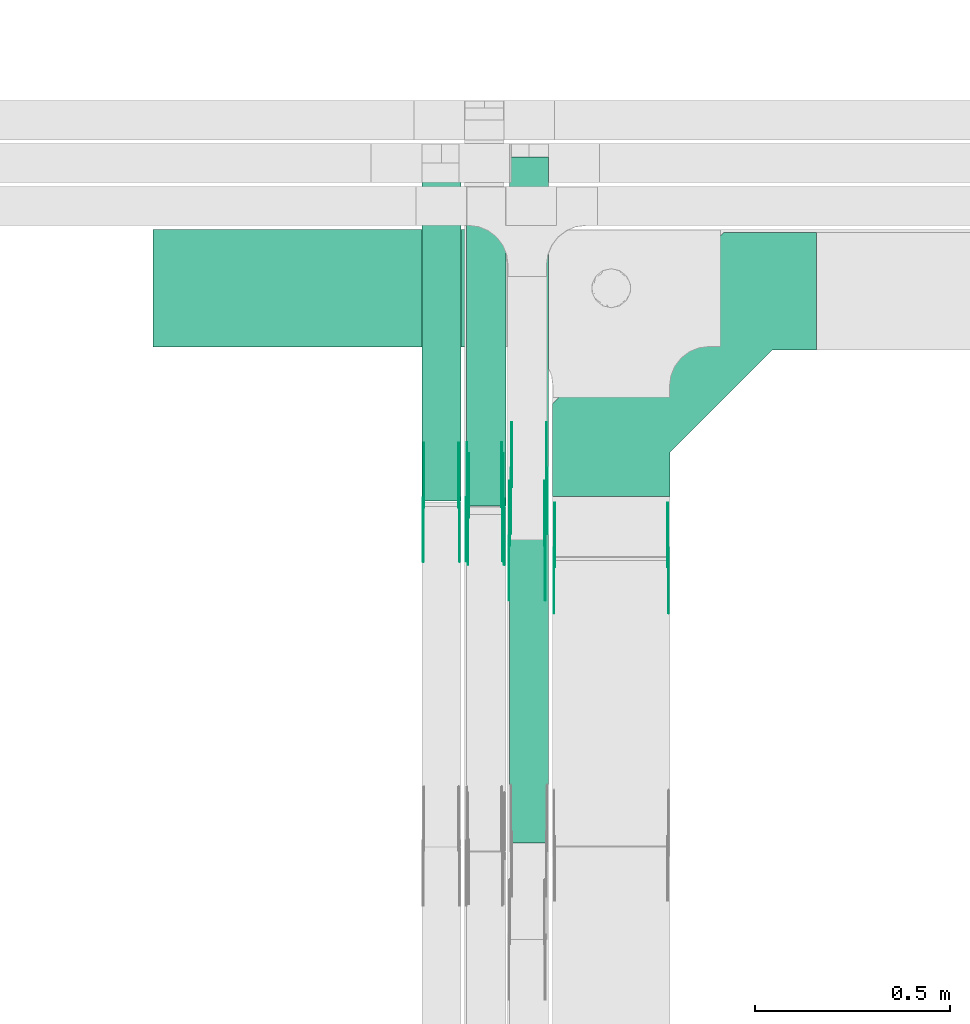
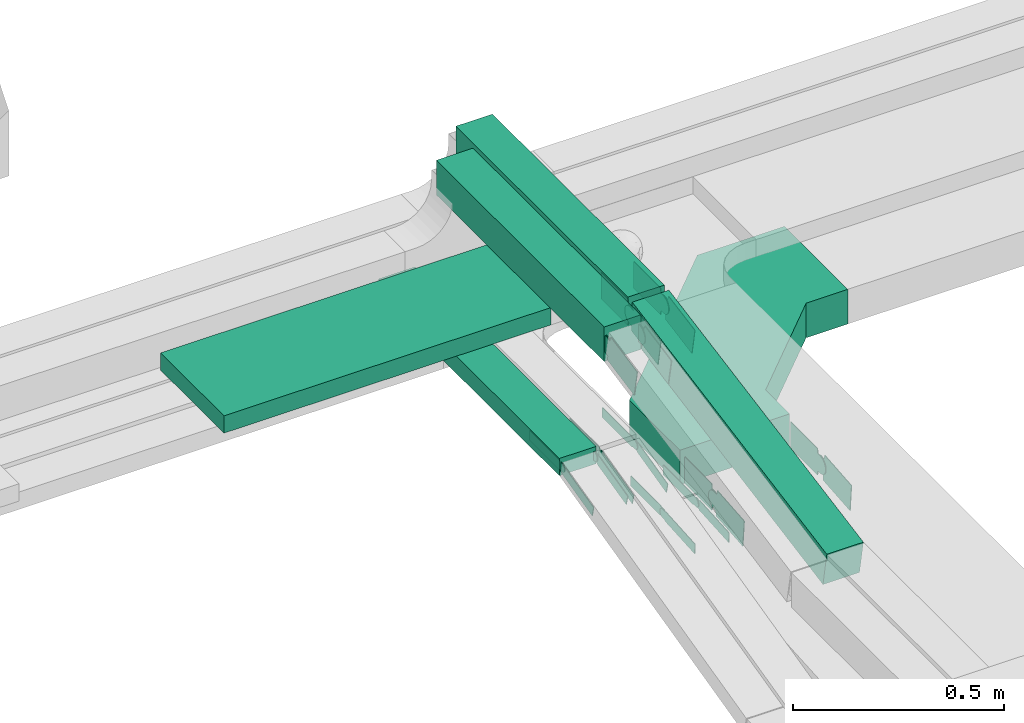
# One storey, part 8 of 32: 25 flow fittings, 5 flow segments.
"""IFC2X3 building model written with IfcOpenShell, lengths in millimetres."""

from ifc_helpers import new_model, entity, si_unit, converted_unit, derived_unit, direction, frame, frame_2d, origin, origin_2d_with_axis, place, context, subcontext, project, spatial, polyline, circle_curve, parameter, trimmed, segment, composite_curve, rectangle, outline, extrude, source, transform, mapped, material, type_object, type_shapes, element, save


model = new_model("IFC2X3")

# Units and contexts
model_context = context("Model", 3, precision=0.01, world=origin(), true_north=direction((6.12303176911189e-17, 1.0)))
body_context = subcontext(model_context, "Body", "Model", "MODEL_VIEW")
ifc_project = project(units=[si_unit("LENGTHUNIT", "METRE", prefix="MILLI"), si_unit("AREAUNIT", "SQUARE_METRE"), si_unit("VOLUMEUNIT", "CUBIC_METRE"), converted_unit("PLANEANGLEUNIT", "DEGREE", entity("IfcRatioMeasure", 0.0174532925199433), si_unit("PLANEANGLEUNIT", "RADIAN"), dimensions=[0, 0, 0, 0, 0, 0, 0]), si_unit("MASSUNIT", "GRAM", prefix="KILO"), derived_unit("MASSDENSITYUNIT", [(si_unit("MASSUNIT", "GRAM", prefix="KILO"), 1), (si_unit("LENGTHUNIT", "METRE"), -3)]), derived_unit("MOMENTOFINERTIAUNIT", [(si_unit("LENGTHUNIT", "METRE"), 4)]), si_unit("TIMEUNIT", "SECOND"), si_unit("FREQUENCYUNIT", "HERTZ"), si_unit("THERMODYNAMICTEMPERATUREUNIT", "DEGREE_CELSIUS"), derived_unit("THERMALTRANSMITTANCEUNIT", [(si_unit("MASSUNIT", "GRAM", prefix="KILO"), 1), (si_unit("THERMODYNAMICTEMPERATUREUNIT", "KELVIN"), -1), (si_unit("TIMEUNIT", "SECOND"), -3)]), derived_unit("VOLUMETRICFLOWRATEUNIT", [(si_unit("LENGTHUNIT", "METRE"), 3), (si_unit("TIMEUNIT", "SECOND"), -1)]), derived_unit("MASSFLOWRATEUNIT", [(si_unit("MASSUNIT", "GRAM", prefix="KILO"), 1), (si_unit("TIMEUNIT", "SECOND"), -1)]), derived_unit("ROTATIONALFREQUENCYUNIT", [(si_unit("TIMEUNIT", "SECOND"), -1)]), si_unit("ELECTRICCURRENTUNIT", "AMPERE"), si_unit("ELECTRICVOLTAGEUNIT", "VOLT"), si_unit("POWERUNIT", "WATT"), si_unit("FORCEUNIT", "NEWTON", prefix="KILO"), si_unit("ILLUMINANCEUNIT", "LUX"), si_unit("LUMINOUSFLUXUNIT", "LUMEN"), si_unit("LUMINOUSINTENSITYUNIT", "CANDELA"), derived_unit("USERDEFINED", [(si_unit("MASSUNIT", "GRAM", prefix="KILO"), -1), (si_unit("LENGTHUNIT", "METRE"), -2), (si_unit("TIMEUNIT", "SECOND"), 3), (si_unit("LUMINOUSFLUXUNIT", "LUMEN"), 1)]), derived_unit("LINEARVELOCITYUNIT", [(si_unit("LENGTHUNIT", "METRE"), 1), (si_unit("TIMEUNIT", "SECOND"), -1)]), si_unit("PRESSUREUNIT", "PASCAL"), derived_unit("USERDEFINED", [(si_unit("LENGTHUNIT", "METRE"), -2), (si_unit("MASSUNIT", "GRAM", prefix="KILO"), 1), (si_unit("TIMEUNIT", "SECOND"), -2)]), derived_unit("LINEARFORCEUNIT", [(si_unit("MASSUNIT", "GRAM", prefix="KILO"), 1), (si_unit("LENGTHUNIT", "METRE"), 1), (si_unit("TIMEUNIT", "SECOND"), -2), (si_unit("LENGTHUNIT", "METRE"), -1)]), derived_unit("PLANARFORCEUNIT", [(si_unit("MASSUNIT", "GRAM", prefix="KILO"), 1), (si_unit("LENGTHUNIT", "METRE"), 1), (si_unit("TIMEUNIT", "SECOND"), -2), (si_unit("LENGTHUNIT", "METRE"), -2)])], contexts=[model_context])

# Site, building, storey
site_placement = place(None, origin())
site = spatial("IfcSite", under=ifc_project, at=site_placement, CompositionType="ELEMENT")
building_placement = place(site_placement, origin())
building = spatial("IfcBuilding", under=site, at=building_placement, CompositionType="ELEMENT")
storey_placement = place(building_placement, frame((0.0, 0.0, 8100.0)))
storey = spatial("IfcBuildingStorey", under=building, at=storey_placement, CompositionType="ELEMENT", Elevation=8100.0)

# Flow segments
cable_carrier_segment_type = type_object("IfcCableCarrierSegmentType", PredefinedType="CABLETRAYSEGMENT")
flow_segment_1_placement = place(storey_placement, frame((17222.5, 14182.28, 2840.02)))
element("IfcFlowSegment", 1, at=flow_segment_1_placement, inside=storey, type_object=cable_carrier_segment_type, context=body_context, shape_type="SweptSolid", body=[
    extrude(rectangle(XDim=893.552364207236, YDim=300.000000000001, at=origin_2d_with_axis()), frame((446.78, 150.0, 0.0), z_axis=(0.0, 0.0, 1.0), x_axis=(-1.0, 0.0, 0.0)), (0.0, 0.0, 1.0), 50.0000000000016),
])
flow_segment_2_placement = place(storey_placement, frame((17911.01, 13787.78, 2715.0)))
element("IfcFlowSegment", 2, at=flow_segment_2_placement, inside=storey, type_object=cable_carrier_segment_type, context=body_context, shape_type="SweptSolid", body=[
    extrude(rectangle(XDim=855.502088397182, YDim=99.9999999999989, at=origin_2d_with_axis()), frame((50.0, 427.75, 0.0), z_axis=(0.0, 0.0, 1.0), x_axis=(0.0, 1.0, 0.0)), (0.0, 0.0, 1.0), 50.0000000000016),
])
flow_segment_3_placement = place(storey_placement, frame((18026.05, 13775.35, 3012.12)))
element("IfcFlowSegment", 3, at=flow_segment_3_placement, inside=storey, type_object=cable_carrier_segment_type, context=body_context, shape_type="SweptSolid", body=[
    extrude(rectangle(XDim=793.729321151489, YDim=99.9999999999989, at=origin_2d_with_axis()), frame((50.0, 396.86, 0.0), z_axis=(0.0, 0.0, 1.0), x_axis=(0.0, -1.0, 0.0)), (0.0, 0.0, 1.0), 99.9999999999989),
])
flow_segment_4_placement = place(storey_placement, frame((18136.05, 13853.76, 3012.12)))
element("IfcFlowSegment", 4, at=flow_segment_4_placement, inside=storey, type_object=cable_carrier_segment_type, context=body_context, shape_type="SweptSolid", body=[
    extrude(rectangle(XDim=814.055739224407, YDim=99.9999999999989, at=origin_2d_with_axis()), frame((50.0, 407.03, 0.0), z_axis=(0.0, 0.0, 1.0), x_axis=(0.0, -1.0, 0.0)), (0.0, 0.0, 1.0), 99.9999999999989),
])
flow_segment_5_placement = place(storey_placement, frame((18136.05, 12912.54, 2841.91)))
element("IfcFlowSegment", 5, at=flow_segment_5_placement, inside=storey, type_object=cable_carrier_segment_type, context=body_context, shape_type="SweptSolid", body=[
    extrude(rectangle(XDim=100.000000000003, YDim=99.9999999999989, at=frame_2d((0.0, 0.0), x_axis=(0.0, 1.0))), frame((50.0, 9.08, 49.17), z_axis=(0.0, 0.983372782908385, 0.181598375089147), x_axis=(-1.0, 0.0, 0.0)), (0.0, 0.0, 1.0), 935.905702587184),
])

# Flow fittings
ifc_material_1 = material()
cable_carrier_fitting_type_1 = type_object("IfcCableCarrierFittingType", Name="470_DKC_G5_Sheet horizontal bend:-", PredefinedType="NOTDEFINED", material=ifc_material_1)
shared_shape_1 = source(origin(), body_context, "Body", "SweptSolid", [
    extrude(outline(polyline([(-307.0, -369.0), (-68.87, -369.0), (369.0, 68.87), (369.0, 307.0), (69.0, 307.0), (69.0, 193.13), (-193.13, -69.0), (-307.0, -69.0), (-307.0, -369.0)])), frame((-219.0, 219.0, -50.0)), (0.0, 0.0, 1.0), 100.0),
])
type_shapes(cable_carrier_fitting_type_1, [shared_shape_1])
flow_fitting_1_placement = place(storey_placement, frame((18396.05, 14324.5, 2615.0), z_axis=(0.0, 0.0, 1.0), x_axis=(-1.0, 0.0, 0.0)))
element("IfcFlowFitting", 6, at=flow_fitting_1_placement, inside=storey, type_object=cable_carrier_fitting_type_1, material=ifc_material_1, Name="470_DKC_G5_Sheet horizontal bend:-", ObjectType="470_DKC_G5_Sheet horizontal bend:-", context=body_context, shape_type="MappedRepresentation", body=[
    mapped(shared_shape_1, transform((0.0, 0.0, 0.0), scale=1.0)),
])
ifc_material_2 = material(Name="G")
cable_carrier_fitting_type_2 = type_object("IfcCableCarrierFittingType", PredefinedType="NOTDEFINED", material=ifc_material_2)
shared_shape_2 = source(origin(), body_context, "Body", "SweptSolid", [
    extrude(outline(composite_curve([segment(trimmed(circle_curve(frame_2d((-44.59, 0.0), x_axis=(1.0, 0.0)), 12.5), [parameter(90.0000000000007)], [parameter(270.0)], True, "PARAMETER"), True, "CONTINUOUS"), segment(polyline([(-44.59, -12.5), (-33.09, -12.5)]), True, "CONTINUOUS"), segment(polyline([(-33.09, -12.5), (-31.23, -14.5)]), True, "CONTINUOUS"), segment(polyline([(-31.23, -14.5), (108.91, -14.5)]), True, "CONTINUOUS"), segment(polyline([(108.91, -14.5), (108.91, 14.5)]), True, "CONTINUOUS"), segment(polyline([(108.91, 14.5), (-31.23, 14.5)]), True, "CONTINUOUS"), segment(polyline([(-31.23, 14.5), (-33.09, 12.5)]), True, "CONTINUOUS"), segment(polyline([(-33.09, 12.5), (-44.59, 12.5)]), True, "CONTINUOUS")], self_intersect=False)), frame((44.59, 0.0, 0.0), z_axis=(0.0, 0.0, -1.0), x_axis=(1.0, 0.0, 0.0)), (0.0, 0.0, -1.0), 2.0),
])
type_shapes(cable_carrier_fitting_type_2, [shared_shape_2])
flow_fitting_2_placement = place(storey_placement, frame((18226.47, 13686.1, 2590.34), z_axis=(1.0, 0.0, 0.0), x_axis=(0.0, -0.99765699277583, -0.068414360813261)))
element("IfcFlowFitting", 7, at=flow_fitting_2_placement, inside=storey, type_object=cable_carrier_fitting_type_2, material=ifc_material_2, context=body_context, shape_type="MappedRepresentation", body=[
    mapped(shared_shape_2, transform((0.0, 0.0, 0.0), scale=1.0)),
])
cable_carrier_fitting_type_3 = type_object("IfcCableCarrierFittingType", PredefinedType="NOTDEFINED", material=ifc_material_2)
type_shapes(cable_carrier_fitting_type_3, [shared_shape_2])
flow_fitting_3_placement = place(storey_placement, frame((18137.55, 13686.1, 2590.34), z_axis=(-1.0, 0.0, 0.0), x_axis=(0.0, 1.0, 0.0)))
element("IfcFlowFitting", 8, at=flow_fitting_3_placement, inside=storey, type_object=cable_carrier_fitting_type_3, material=ifc_material_2, context=body_context, shape_type="MappedRepresentation", body=[
    mapped(shared_shape_2, transform((0.0, 0.0, 0.0), scale=1.0)),
])
flow_fitting_4_placement = place(storey_placement, frame((18006.47, 13783.28, 2740.0), z_axis=(1.0, 0.0, 0.0), x_axis=(0.0, -0.971320023080273, -0.237775971795593)))
element("IfcFlowFitting", 9, at=flow_fitting_4_placement, inside=storey, type_object=cable_carrier_fitting_type_2, material=ifc_material_2, context=body_context, shape_type="MappedRepresentation", body=[
    mapped(shared_shape_2, transform((0.0, 0.0, 0.0), scale=1.0)),
])
flow_fitting_5_placement = place(storey_placement, frame((17917.55, 13783.28, 2740.0), z_axis=(-1.0, 0.0, 0.0), x_axis=(0.0, 1.0, 0.0)))
element("IfcFlowFitting", 10, at=flow_fitting_5_placement, inside=storey, type_object=cable_carrier_fitting_type_3, material=ifc_material_2, context=body_context, shape_type="MappedRepresentation", body=[
    mapped(shared_shape_2, transform((0.0, 0.0, 0.0), scale=1.0)),
])
flow_fitting_6_placement = place(storey_placement, frame((18116.47, 13784.33, 2735.72), z_axis=(1.0, 0.0, 0.0), x_axis=(0.0, -0.971320023080273, -0.237775971795593)))
element("IfcFlowFitting", 11, at=flow_fitting_6_placement, inside=storey, type_object=cable_carrier_fitting_type_2, material=ifc_material_2, context=body_context, shape_type="MappedRepresentation", body=[
    mapped(shared_shape_2, transform((0.0, 0.0, 0.0), scale=1.0)),
])
flow_fitting_7_placement = place(storey_placement, frame((18027.55, 13784.33, 2735.72), z_axis=(-1.0, 0.0, 0.0), x_axis=(0.0, 1.0, 0.0)))
element("IfcFlowFitting", 12, at=flow_fitting_7_placement, inside=storey, type_object=cable_carrier_fitting_type_3, material=ifc_material_2, context=body_context, shape_type="MappedRepresentation", body=[
    mapped(shared_shape_2, transform((0.0, 0.0, 0.0), scale=1.0)),
])
cable_carrier_fitting_type_4 = type_object("IfcCableCarrierFittingType", PredefinedType="NOTDEFINED", material=ifc_material_2)
shared_shape_3 = source(origin(), body_context, "Body", "SweptSolid", [
    extrude(outline(composite_curve([segment(trimmed(circle_curve(frame_2d((-44.59, 0.0), x_axis=(1.0, 0.0)), 12.5), [parameter(90.0000000000007)], [parameter(270.0)], True, "PARAMETER"), True, "CONTINUOUS"), segment(polyline([(-44.59, -12.5), (-33.09, -12.5)]), True, "CONTINUOUS"), segment(polyline([(-33.09, -12.5), (-31.23, -14.5)]), True, "CONTINUOUS"), segment(polyline([(-31.23, -14.5), (108.91, -14.5)]), True, "CONTINUOUS"), segment(polyline([(108.91, -14.5), (108.91, 14.5)]), True, "CONTINUOUS"), segment(polyline([(108.91, 14.5), (-31.23, 14.5)]), True, "CONTINUOUS"), segment(polyline([(-31.23, 14.5), (-33.09, 12.5)]), True, "CONTINUOUS"), segment(polyline([(-33.09, 12.5), (-44.59, 12.5)]), True, "CONTINUOUS")], self_intersect=False)), frame((44.59, 0.0, 0.0)), (0.0, 0.0, 1.0), 2.0),
])
type_shapes(cable_carrier_fitting_type_4, [shared_shape_3])
flow_fitting_8_placement = place(storey_placement, frame((18135.55, 13686.1, 2590.34), z_axis=(-1.0, 0.0, 0.0), x_axis=(0.0, -0.99765699277583, -0.068414360813261)))
element("IfcFlowFitting", 13, at=flow_fitting_8_placement, inside=storey, type_object=cable_carrier_fitting_type_4, material=ifc_material_2, context=body_context, shape_type="MappedRepresentation", body=[
    mapped(shared_shape_3, transform((0.0, 0.0, 0.0), scale=1.0)),
])
cable_carrier_fitting_type_5 = type_object("IfcCableCarrierFittingType", PredefinedType="NOTDEFINED", material=ifc_material_2)
type_shapes(cable_carrier_fitting_type_5, [shared_shape_3])
flow_fitting_9_placement = place(storey_placement, frame((18224.47, 13686.1, 2590.34), z_axis=(1.0, 0.0, 0.0), x_axis=(0.0, 1.0, 0.0)))
element("IfcFlowFitting", 14, at=flow_fitting_9_placement, inside=storey, type_object=cable_carrier_fitting_type_5, material=ifc_material_2, context=body_context, shape_type="MappedRepresentation", body=[
    mapped(shared_shape_3, transform((0.0, 0.0, 0.0), scale=1.0)),
])
flow_fitting_10_placement = place(storey_placement, frame((17915.55, 13783.28, 2740.0), z_axis=(-1.0, 0.0, 0.0), x_axis=(0.0, -0.971320023080273, -0.237775971795593)))
element("IfcFlowFitting", 15, at=flow_fitting_10_placement, inside=storey, type_object=cable_carrier_fitting_type_4, material=ifc_material_2, context=body_context, shape_type="MappedRepresentation", body=[
    mapped(shared_shape_3, transform((0.0, 0.0, 0.0), scale=1.0)),
])
flow_fitting_11_placement = place(storey_placement, frame((18004.47, 13783.28, 2740.0), z_axis=(1.0, 0.0, 0.0), x_axis=(0.0, 1.0, 0.0)))
element("IfcFlowFitting", 16, at=flow_fitting_11_placement, inside=storey, type_object=cable_carrier_fitting_type_5, material=ifc_material_2, context=body_context, shape_type="MappedRepresentation", body=[
    mapped(shared_shape_3, transform((0.0, 0.0, 0.0), scale=1.0)),
])
flow_fitting_12_placement = place(storey_placement, frame((18025.55, 13784.33, 2735.72), z_axis=(-1.0, 0.0, 0.0), x_axis=(0.0, -0.971320023080273, -0.237775971795593)))
element("IfcFlowFitting", 17, at=flow_fitting_12_placement, inside=storey, type_object=cable_carrier_fitting_type_4, material=ifc_material_2, context=body_context, shape_type="MappedRepresentation", body=[
    mapped(shared_shape_3, transform((0.0, 0.0, 0.0), scale=1.0)),
])
flow_fitting_13_placement = place(storey_placement, frame((18114.47, 13784.33, 2735.72), z_axis=(1.0, 0.0, 0.0), x_axis=(0.0, 1.0, 0.0)))
element("IfcFlowFitting", 18, at=flow_fitting_13_placement, inside=storey, type_object=cable_carrier_fitting_type_5, material=ifc_material_2, context=body_context, shape_type="MappedRepresentation", body=[
    mapped(shared_shape_3, transform((0.0, 0.0, 0.0), scale=1.0)),
])
cable_carrier_fitting_type_6 = type_object("IfcCableCarrierFittingType", PredefinedType="NOTDEFINED", material=ifc_material_2)
shared_shape_4 = source(origin(), body_context, "Body", "SweptSolid", [
    extrude(outline(composite_curve([segment(trimmed(circle_curve(frame_2d((-41.47, 0.0), x_axis=(1.0, 0.0)), 25.0), [parameter(90.0000000000007)], [parameter(270.0)], True, "PARAMETER"), True, "CONTINUOUS"), segment(polyline([(-41.47, -25.0), (-29.97, -25.0)]), True, "CONTINUOUS"), segment(polyline([(-29.97, -25.0), (-28.1, -38.5)]), True, "CONTINUOUS"), segment(polyline([(-28.1, -38.5), (99.53, -38.5)]), True, "CONTINUOUS"), segment(polyline([(99.53, -38.5), (99.53, 38.5)]), True, "CONTINUOUS"), segment(polyline([(99.53, 38.5), (-28.1, 38.5)]), True, "CONTINUOUS"), segment(polyline([(-28.1, 38.5), (-29.97, 25.0)]), True, "CONTINUOUS"), segment(polyline([(-29.97, 25.0), (-41.47, 25.0)]), True, "CONTINUOUS")], self_intersect=False)), frame((41.47, 0.0, 0.0), z_axis=(0.0, 0.0, -1.0), x_axis=(1.0, 0.0, 0.0)), (0.0, 0.0, -1.0), 2.0),
])
type_shapes(cable_carrier_fitting_type_6, [shared_shape_4])
flow_fitting_14_placement = place(storey_placement, frame((18541.51, 13642.5, 2615.0), z_axis=(1.0, 0.0, 0.0), x_axis=(0.0, -0.996138692653759, -0.0877935361974902)))
element("IfcFlowFitting", 19, at=flow_fitting_14_placement, inside=storey, type_object=cable_carrier_fitting_type_6, material=ifc_material_2, context=body_context, shape_type="MappedRepresentation", body=[
    mapped(shared_shape_4, transform((0.0, 0.0, 0.0), scale=1.0)),
])
cable_carrier_fitting_type_7 = type_object("IfcCableCarrierFittingType", PredefinedType="NOTDEFINED", material=ifc_material_2)
type_shapes(cable_carrier_fitting_type_7, [shared_shape_4])
flow_fitting_15_placement = place(storey_placement, frame((18252.59, 13642.5, 2615.0), z_axis=(-1.0, 0.0, 0.0), x_axis=(0.0, 1.0, 0.0)))
element("IfcFlowFitting", 20, at=flow_fitting_15_placement, inside=storey, type_object=cable_carrier_fitting_type_7, material=ifc_material_2, context=body_context, shape_type="MappedRepresentation", body=[
    mapped(shared_shape_4, transform((0.0, 0.0, 0.0), scale=1.0)),
])
flow_fitting_16_placement = place(storey_placement, frame((18231.51, 13847.81, 3062.12), z_axis=(1.0, 0.0, 0.0), x_axis=(0.0, -0.983372782908371, -0.181598375089224)))
element("IfcFlowFitting", 21, at=flow_fitting_16_placement, inside=storey, type_object=cable_carrier_fitting_type_6, material=ifc_material_2, context=body_context, shape_type="MappedRepresentation", body=[
    mapped(shared_shape_4, transform((0.0, 0.0, 0.0), scale=1.0)),
])
flow_fitting_17_placement = place(storey_placement, frame((18142.59, 13847.81, 3062.12), z_axis=(-1.0, 0.0, 0.0), x_axis=(0.0, 1.0, 0.0)))
element("IfcFlowFitting", 22, at=flow_fitting_17_placement, inside=storey, type_object=cable_carrier_fitting_type_7, material=ifc_material_2, context=body_context, shape_type="MappedRepresentation", body=[
    mapped(shared_shape_4, transform((0.0, 0.0, 0.0), scale=1.0)),
])
flow_fitting_18_placement = place(storey_placement, frame((18121.51, 13769.08, 3062.12), z_axis=(1.0, 0.0, 0.0), x_axis=(0.0, -0.981126269625946, -0.193368154177143)))
element("IfcFlowFitting", 23, at=flow_fitting_18_placement, inside=storey, type_object=cable_carrier_fitting_type_6, material=ifc_material_2, context=body_context, shape_type="MappedRepresentation", body=[
    mapped(shared_shape_4, transform((0.0, 0.0, 0.0), scale=1.0)),
])
flow_fitting_19_placement = place(storey_placement, frame((18032.59, 13769.08, 3062.12), z_axis=(-1.0, 0.0, 0.0), x_axis=(0.0, 1.0, 0.0)))
element("IfcFlowFitting", 24, at=flow_fitting_19_placement, inside=storey, type_object=cable_carrier_fitting_type_7, material=ifc_material_2, context=body_context, shape_type="MappedRepresentation", body=[
    mapped(shared_shape_4, transform((0.0, 0.0, 0.0), scale=1.0)),
])
cable_carrier_fitting_type_8 = type_object("IfcCableCarrierFittingType", PredefinedType="NOTDEFINED", material=ifc_material_2)
shared_shape_5 = source(origin(), body_context, "Body", "SweptSolid", [
    extrude(outline(composite_curve([segment(trimmed(circle_curve(frame_2d((-41.47, 0.0), x_axis=(1.0, 0.0)), 25.0), [parameter(90.0000000000007)], [parameter(270.0)], True, "PARAMETER"), True, "CONTINUOUS"), segment(polyline([(-41.47, -25.0), (-29.97, -25.0)]), True, "CONTINUOUS"), segment(polyline([(-29.97, -25.0), (-28.1, -38.5)]), True, "CONTINUOUS"), segment(polyline([(-28.1, -38.5), (99.53, -38.5)]), True, "CONTINUOUS"), segment(polyline([(99.53, -38.5), (99.53, 38.5)]), True, "CONTINUOUS"), segment(polyline([(99.53, 38.5), (-28.1, 38.5)]), True, "CONTINUOUS"), segment(polyline([(-28.1, 38.5), (-29.97, 25.0)]), True, "CONTINUOUS"), segment(polyline([(-29.97, 25.0), (-41.47, 25.0)]), True, "CONTINUOUS")], self_intersect=False)), frame((41.47, 0.0, 0.0)), (0.0, 0.0, 1.0), 2.0),
])
type_shapes(cable_carrier_fitting_type_8, [shared_shape_5])
flow_fitting_20_placement = place(storey_placement, frame((18250.59, 13642.5, 2615.0), z_axis=(-1.0, 0.0, 0.0), x_axis=(0.0, -0.996138692653759, -0.0877935361974902)))
element("IfcFlowFitting", 25, at=flow_fitting_20_placement, inside=storey, type_object=cable_carrier_fitting_type_8, material=ifc_material_2, context=body_context, shape_type="MappedRepresentation", body=[
    mapped(shared_shape_5, transform((0.0, 0.0, 0.0), scale=1.0)),
])
cable_carrier_fitting_type_9 = type_object("IfcCableCarrierFittingType", PredefinedType="NOTDEFINED", material=ifc_material_2)
type_shapes(cable_carrier_fitting_type_9, [shared_shape_5])
flow_fitting_21_placement = place(storey_placement, frame((18539.51, 13642.5, 2615.0), z_axis=(1.0, 0.0, 0.0), x_axis=(0.0, 1.0, 0.0)))
element("IfcFlowFitting", 26, at=flow_fitting_21_placement, inside=storey, type_object=cable_carrier_fitting_type_9, material=ifc_material_2, context=body_context, shape_type="MappedRepresentation", body=[
    mapped(shared_shape_5, transform((0.0, 0.0, 0.0), scale=1.0)),
])
flow_fitting_22_placement = place(storey_placement, frame((18140.59, 13847.81, 3062.12), z_axis=(-1.0, 0.0, 0.0), x_axis=(0.0, -0.983372782908371, -0.181598375089224)))
element("IfcFlowFitting", 27, at=flow_fitting_22_placement, inside=storey, type_object=cable_carrier_fitting_type_8, material=ifc_material_2, context=body_context, shape_type="MappedRepresentation", body=[
    mapped(shared_shape_5, transform((0.0, 0.0, 0.0), scale=1.0)),
])
flow_fitting_23_placement = place(storey_placement, frame((18229.51, 13847.81, 3062.12), z_axis=(1.0, 0.0, 0.0), x_axis=(0.0, 1.0, 0.0)))
element("IfcFlowFitting", 28, at=flow_fitting_23_placement, inside=storey, type_object=cable_carrier_fitting_type_9, material=ifc_material_2, context=body_context, shape_type="MappedRepresentation", body=[
    mapped(shared_shape_5, transform((0.0, 0.0, 0.0), scale=1.0)),
])
flow_fitting_24_placement = place(storey_placement, frame((18030.59, 13769.08, 3062.12), z_axis=(-1.0, 0.0, 0.0), x_axis=(0.0, -0.981126269625946, -0.193368154177143)))
element("IfcFlowFitting", 29, at=flow_fitting_24_placement, inside=storey, type_object=cable_carrier_fitting_type_8, material=ifc_material_2, context=body_context, shape_type="MappedRepresentation", body=[
    mapped(shared_shape_5, transform((0.0, 0.0, 0.0), scale=1.0)),
])
flow_fitting_25_placement = place(storey_placement, frame((18119.51, 13769.08, 3062.12), z_axis=(1.0, 0.0, 0.0), x_axis=(0.0, 1.0, 0.0)))
element("IfcFlowFitting", 30, at=flow_fitting_25_placement, inside=storey, type_object=cable_carrier_fitting_type_9, material=ifc_material_2, context=body_context, shape_type="MappedRepresentation", body=[
    mapped(shared_shape_5, transform((0.0, 0.0, 0.0), scale=1.0)),
])

save(model, "model.ifc")
